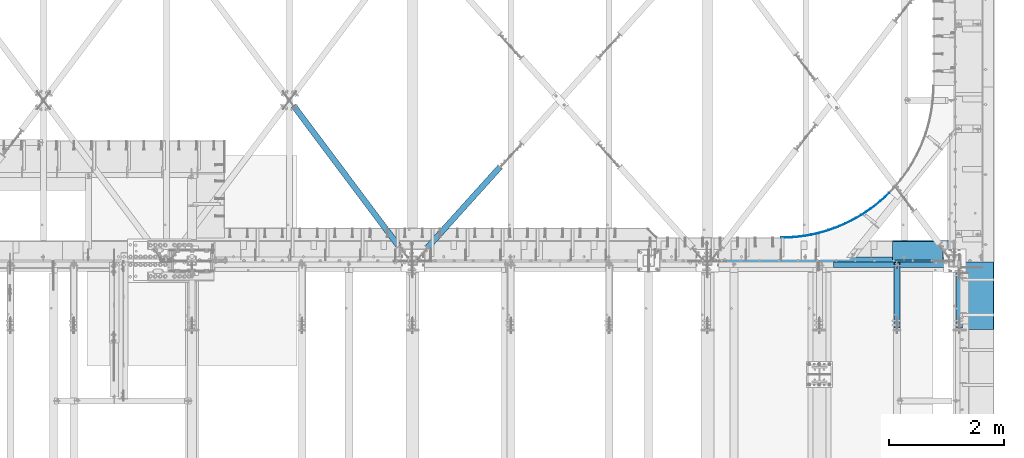
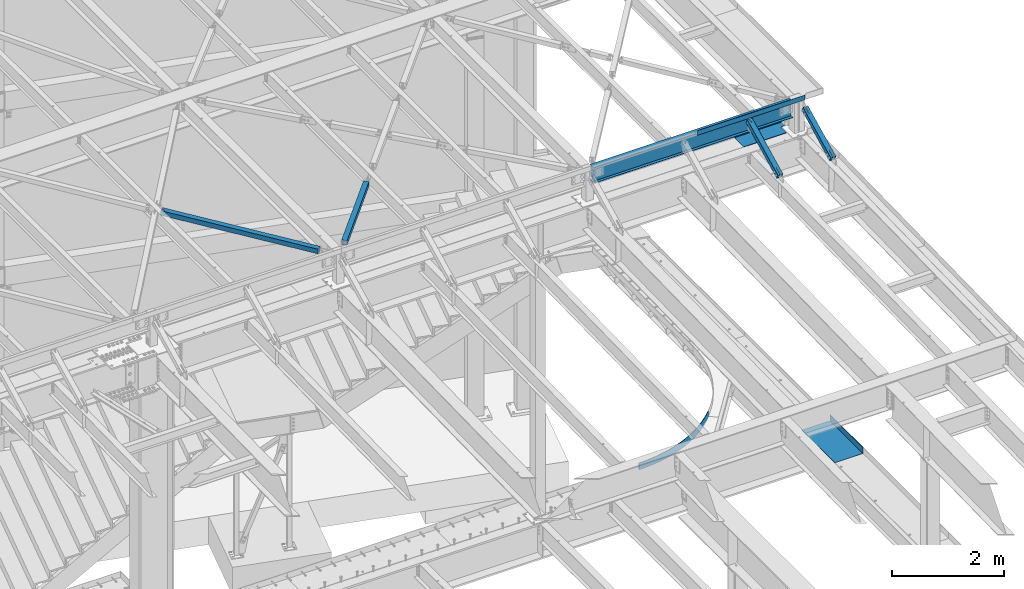
# One storey, part 1165 of 1763: 7 beams, 2 members, 8 elements without a shape of their own.
"""IFC2X3 building model written with IfcOpenShell, lengths in millimetres."""

from ifc_helpers import new_model, si_unit, frame, origin_with_axes, place, context, subcontext, project, spatial, faceted_brep, material, type_object, element, aggregate, save


model = new_model("IFC2X3")

# Units and contexts
model_context = context("Model", 3, precision=1e-05, world=origin_with_axes())
body_context = subcontext(model_context, "Body", "Model", "MODEL_VIEW")
ifc_project = project(units=[si_unit("LENGTHUNIT", "METRE", prefix="MILLI"), si_unit("AREAUNIT", "SQUARE_METRE"), si_unit("VOLUMEUNIT", "CUBIC_METRE"), si_unit("MASSUNIT", "GRAM", prefix="KILO"), si_unit("TIMEUNIT", "SECOND"), si_unit("PLANEANGLEUNIT", "RADIAN"), si_unit("SOLIDANGLEUNIT", "STERADIAN"), si_unit("THERMODYNAMICTEMPERATUREUNIT", "DEGREE_CELSIUS"), si_unit("LUMINOUSINTENSITYUNIT", "LUMEN")], contexts=[model_context])

# Site, building, storey
site_placement = place(None, origin_with_axes())
site = spatial("IfcSite", under=ifc_project, at=site_placement, CompositionType="ELEMENT")
building_placement = place(site_placement, origin_with_axes())
building = spatial("IfcBuilding", under=site, at=building_placement, Name="Undefined", CompositionType="ELEMENT")
storey_placement = place(building_placement, origin_with_axes())
storey = spatial("IfcBuildingStorey", under=building, at=storey_placement, Name="Undefined", CompositionType="ELEMENT", Elevation=0.0)

# Assembly, beam
assembly_1_placement = place(storey_placement, origin_with_axes())
assembly_1 = element("IfcElementAssembly", 1, at=assembly_1_placement, inside=storey, Name="BEAM", AssemblyPlace="NOTDEFINED", PredefinedType="RIGID_FRAME")
ifc_material_1 = material(Name="STEEL/A36")
beam_type_1 = type_object("IfcBeamType", Name="L4X4X1/4", PredefinedType="NOTDEFINED")
beam_1_placement = place(assembly_1_placement, frame((-23782.8433674464, 52050.95, 12496.8), z_axis=(0.0, 1.0, 0.0), x_axis=(1.0, 0.0, 0.0)))
beam_1 = element("IfcBeam", 2, at=beam_1_placement, type_object=beam_type_1, material=ifc_material_1, Name="V. BRACE", ObjectType="L4X4X1/4", context=body_context, shape_type="Brep", body=[
    faceted_brep([(1998.50375037947, 44.4500000000007, 50.8000000000029), (1998.50375037947, 44.4500000000007, -44.4499999999971), (1998.50375037947, 50.7999999999938, -44.4499999999898), (1998.50375037947, 50.7999999999993, 50.8000000000029), (2212.81625000197, 44.4500000000007, -44.4499999999971), (2212.81625000197, 50.7999999999993, -44.4499999999898), (2.11002770811319e-10, -50.8000000000357, -50.799999999952), (1.96450855582952e-10, -50.8000000000338, -44.4499999999534), (-2.18278728425503e-11, 44.4500000000007, -44.450000000048), (-1.81898940354586e-10, 44.4500000000371, 50.7999999999374), (-1.96450855582952e-10, 50.8000000000393, 50.7999999999374), (-3.63797880709171e-11, 50.8000000000011, -50.8000000000538), (2212.81625000197, 50.7999999999993, -50.8000000000029), (2212.81625000197, -50.7999999999993, -50.8000000000029), (2212.81625000197, -50.7999999999993, -44.4499999999971), (2212.81625000197, 31.7499999999945, -44.4499999999971)], [[[0, 1, 2, 3]], [[4, 5, 2, 1]], [[6, 7, 8, 9, 10, 11]], [[6, 11, 12, 13]], [[7, 6, 13, 14]], [[1, 8, 7, 14, 15, 4]], [[9, 8, 1, 0]], [[10, 9, 0, 3]], [[12, 11, 10, 3, 2, 5]], [[15, 14, 13, 12, 5, 4]]]),
])

assembly_2_placement = place(storey_placement, origin_with_axes())
assembly_2 = element("IfcElementAssembly", 3, at=assembly_2_placement, inside=storey, Name="BEAM", AssemblyPlace="NOTDEFINED", PredefinedType="RIGID_FRAME")
beam_type_2 = type_object("IfcBeamType", PredefinedType="NOTDEFINED")
beam_2_placement = place(assembly_2_placement, frame((-21576.7372736984, 51509.2155, 5199.0625), z_axis=(0.0, -1.0, 0.0), x_axis=(1.0, 0.0, 0.0)))
beam_2 = element("IfcBeam", 4, at=beam_2_placement, type_object=beam_type_2, material=ifc_material_1, Name="BENT_PLATE", context=body_context, shape_type="Brep", body=[
    faceted_brep([(0.0, -4.76249999999982, -588.565499999997), (0.0, -4.76249999999982, 588.565499999997), (0.0, 4.76249999999982, 588.565499999997), (0.0, 4.76249999999982, -588.565499999997), (577.849999999999, 4.76249999999982, 588.565499999997), (577.849999999999, 4.76249999999982, -588.565499999997), (587.375, -4.76249999999982, -588.565499999997), (587.375, -4.76249999999982, 588.565499999997), (577.849999999999, 134.937496948242, 588.565499999997), (577.849999999999, 134.937496948242, -588.565499999997), (587.375, 134.937496948242, 588.565499999997), (587.375, 134.937496948242, -588.565499999997)], [[[0, 1, 2, 3]], [[3, 2, 4, 5]], [[1, 0, 6, 7]], [[5, 4, 8, 9]], [[4, 2, 1, 7, 10, 8]], [[7, 6, 11, 10]], [[6, 0, 3, 5, 9, 11]], [[10, 11, 9, 8]]]),
])
aggregate(assembly_2, [beam_2])

assembly_3_placement = place(storey_placement, origin_with_axes())
assembly_3 = element("IfcElementAssembly", 5, at=assembly_3_placement, inside=storey, Name="BEAM", AssemblyPlace="NOTDEFINED", PredefinedType="RIGID_FRAME")
beam_type_3 = type_object("IfcBeamType", PredefinedType="NOTDEFINED")
beam_3_placement = place(assembly_3_placement, frame((-24688.4513631793, 52522.4379788748, 5245.1), z_axis=(0.0, 0.0, 1.0), x_axis=(0.923270562101468, 0.384150321042218, 0.0)))
beam_3 = element("IfcBeam", 6, at=beam_3_placement, type_object=beam_type_3, material=ifc_material_1, Name="PLATE", context=body_context, shape_type="Brep", body=[
    faceted_brep([(1.82766043285983, 4.39784760903422, -76.1999999999998), (1.82766043285983, 4.39784760903422, 76.1999999999998), (98.6660821309192, -33.6277689342314, 76.1999999999998), (98.6660821309192, -33.6277689342314, -76.1999999999998), (-1.82766043286802, -4.39784760901966, 76.1999999999998), (-1.82766043286802, -4.39784760901966, -76.1999999999998), (95.3599385969715, -42.5605758801612, -76.1999999999998), (95.3599385969715, -42.5605758801612, 76.1999999999998), (196.926711149033, -67.8107503055435, 76.1999999999998), (196.926711149033, -67.8107503055435, -76.1999999999998), (193.97487310311, -76.8668133105748, -76.1999999999998), (193.97487310311, -76.8668133105748, 76.1999999999998), (296.457135514323, -98.0980753133772, 76.1999999999998), (296.457135514323, -98.0980753133772, -76.1999999999998), (293.86418154975, -107.26334752635, -76.1999999999998), (293.86418154975, -107.26334752635, 76.1999999999998), (397.102973675515, -124.442765315303, 76.1999999999998), (397.102973675515, -124.442765315303, -76.1999999999998), (394.872925720836, -133.703030490775, -76.1999999999998), (394.872925720836, -133.703030490775, 76.1999999999998), (498.708113963984, -146.803957086442, 76.1999999999998), (498.708113963984, -146.803957086442, -76.1999999999998), (496.84443104457, -156.144851635487, -76.1999999999998), (496.84443104457, -156.144851635487, 76.1999999999998), (601.114956738452, -165.146966202461, 76.1999999999998), (601.114956738452, -165.146966202461, -76.1999999999998), (599.620529611194, -174.554001471966, -76.1999999999998), (599.620529611194, -174.554001471966, 76.1999999999998), (704.164658837635, -179.443340838501, 76.1999999999998), (704.164658837635, -179.443340838501, -76.1999999999998), (703.041805507109, -188.901925584563, -76.1999999999998), (703.041805507109, -188.901925584563, 76.1999999999998), (807.697379961744, -189.670905900777, 76.1999999999998), (807.697379961744, -189.670905900777, -76.1999999999998), (806.947842084726, -199.166368921149, -76.1999999999998), (806.947842084726, -199.166368921149, 76.1999999999998), (911.552530600609, -195.813797422357, 76.1999999999998), (911.552530600609, -195.813797422357, -76.1999999999998), (911.177470784623, -205.331410312931, -76.1999999999998), (911.177470784623, -205.331410312931, 76.1999999999998), (1015.56902112392, -197.862487169776, 76.1999999999998), (1015.56902112392, -197.862487169776, -76.1999999999998), (1015.56902112391, -207.387487169792, -76.1999999999998), (1015.56902112391, -207.387487169792, 76.1999999999998), (1119.58551164723, -195.81379742219, 76.1999999999998), (1119.58551164723, -195.81379742219, -76.1999999999998), (1119.9605714632, -205.331410312763, -76.1999999999998), (1119.9605714632, -205.331410312763, 76.1999999999998), (1223.4406622861, -189.670905900428, 76.1999999999998), (1223.4406622861, -189.670905900428, -76.1999999999998), (1224.19020016311, -199.166368920814, -76.1999999999998), (1224.19020016311, -199.166368920814, 76.1999999999998), (1326.97338341022, -179.443340837999, 76.1999999999998), (1326.97338341022, -179.443340837999, -76.1999999999998), (1328.09623674073, -188.901925584061, -76.1999999999998), (1328.09623674073, -188.901925584061, 76.1999999999998), (1430.02308550943, -165.146966201792, 76.1999999999998), (1430.02308550943, -165.146966201792, -76.1999999999998), (1431.51751263667, -174.554001471297, -76.1999999999998), (1431.51751263667, -174.554001471297, 76.1999999999998), (1532.42992828391, -146.803957085605, 76.1999999999998), (1532.42992828391, -146.803957085605, -76.1999999999998), (1534.29361120332, -156.144851634635, -76.1999999999998), (1534.29361120332, -156.144851634635, 76.1999999999998), (1634.03506857241, -124.442765314292, 76.1999999999998), (1634.03506857241, -124.442765314292, -76.1999999999998), (1636.26511652707, -133.703030489771, -76.1999999999998), (1636.26511652707, -133.703030489771, 76.1999999999998), (1734.68090673362, -98.0980753122058, 76.1999999999998), (1734.68090673362, -98.0980753122058, -76.1999999999998), (1737.27386069819, -107.263347525186, -76.1999999999998), (1737.27386069819, -107.263347525186, 76.1999999999998), (1834.21133109895, -67.8107503042193, 76.1999999999998), (1834.21133109895, -67.8107503042193, -76.1999999999998), (1837.16316914487, -76.866813309236, -76.1999999999998), (1837.16316914487, -76.866813309236, 76.1999999999998), (1932.47196011711, -33.6277689327471, 76.1999999999998), (1932.47196011711, -33.6277689327471, -76.1999999999998), (1935.77810365104, -42.5605758786769, -76.1999999999998), (1935.77810365104, -42.5605758786769, 76.1999999999998), (2029.31038181521, 4.39784761067858, 76.1999999999998), (2029.31038181521, 4.39784761067858, -76.1999999999998), (2032.96570268093, -4.3978476073753, 76.1999999999998), (2032.96570268093, -4.3978476073753, -76.1999999999998)], [[[0, 1, 2, 3]], [[4, 5, 6, 7]], [[5, 4, 1, 0]], [[3, 2, 8, 9]], [[7, 6, 10, 11]], [[9, 8, 12, 13]], [[11, 10, 14, 15]], [[13, 12, 16, 17]], [[15, 14, 18, 19]], [[17, 16, 20, 21]], [[19, 18, 22, 23]], [[21, 20, 24, 25]], [[23, 22, 26, 27]], [[25, 24, 28, 29]], [[27, 26, 30, 31]], [[29, 28, 32, 33]], [[31, 30, 34, 35]], [[33, 32, 36, 37]], [[35, 34, 38, 39]], [[37, 36, 40, 41]], [[39, 38, 42, 43]], [[41, 40, 44, 45]], [[43, 42, 46, 47]], [[45, 44, 48, 49]], [[47, 46, 50, 51]], [[49, 48, 52, 53]], [[51, 50, 54, 55]], [[53, 52, 56, 57]], [[55, 54, 58, 59]], [[57, 56, 60, 61]], [[59, 58, 62, 63]], [[61, 60, 64, 65]], [[63, 62, 66, 67]], [[65, 64, 68, 69]], [[67, 66, 70, 71]], [[69, 68, 72, 73]], [[71, 70, 74, 75]], [[73, 72, 76, 77]], [[75, 74, 78, 79]], [[77, 76, 80, 81]], [[76, 72, 68, 64, 60, 56, 52, 48, 44, 40, 36, 32, 28, 24, 20, 16, 12, 8, 2, 1, 4, 7, 11, 15, 19, 23, 27, 31, 35, 39, 43, 47, 51, 55, 59, 63, 67, 71, 75, 79, 82, 80]], [[79, 78, 83, 82]], [[78, 74, 70, 66, 62, 58, 54, 50, 46, 42, 38, 34, 30, 26, 22, 18, 14, 10, 6, 5, 0, 3, 9, 13, 17, 21, 25, 29, 33, 37, 41, 45, 49, 53, 57, 61, 65, 69, 73, 77, 81, 83]], [[82, 83, 81, 80]]]),
])
aggregate(assembly_3, [beam_3])

assembly_4_placement = place(storey_placement, origin_with_axes())
assembly_4 = element("IfcElementAssembly", 7, at=assembly_4_placement, inside=storey, Name="H. BRACE", AssemblyPlace="NOTDEFINED", PredefinedType="RIGID_FRAME")
ifc_material_2 = material()
beam_type_4 = type_object("IfcBeamType", Name="HSS4X4X3/8", PredefinedType="NOTDEFINED")
beam_4_placement = place(assembly_4_placement, frame((-29400.5296174484, 53960.2116756962, 12371.3875), z_axis=(0.0, 0.0, 1.0), x_axis=(-0.669524421073345, -0.742790044081369, 0.0)))
beam_4 = element("IfcBeam", 8, at=beam_4_placement, type_object=beam_type_4, material=ifc_material_2, Name="H. BRACE", ObjectType="HSS4X4X3/8", context=body_context, shape_type="Brep", body=[
    faceted_brep([(280.94314391946, 41.2749999996377, -41.2749999999996), (280.943143919689, -41.2750000002634, -41.2749999999996), (2162.19987088826, -41.2750000023079, -41.2749999999996), (2162.19987088803, 41.2749999976004, -41.2749999999996), (280.943143919689, -41.2750000002634, 41.2749999999996), (2162.19987088826, -41.2750000023079, 41.2749999999996), (280.94314391946, 41.2749999996377, 41.2749999999996), (2162.19987088803, 41.2749999976004, 41.2749999999996), (280.943143919434, 50.7999999996318, -50.7999999999993), (280.943143919434, 50.7999999996318, 50.7999999999993), (2162.19987088801, 50.7999999975946, 50.7999999999993), (2162.19987088801, 50.7999999975946, -50.7999999999993), (280.943143919714, -50.8000000002576, 50.7999999999993), (2162.19987088829, -50.8000000022948, 50.7999999999993), (280.943143919714, -50.8000000002576, -50.7999999999993), (2162.19987088829, -50.8000000022948, -50.7999999999993)], [[[0, 1, 2, 3]], [[1, 4, 5, 2]], [[4, 6, 7, 5]], [[6, 0, 3, 7]], [[8, 9, 10, 11]], [[9, 12, 13, 10]], [[12, 14, 15, 13]], [[14, 8, 11, 15]], [[13, 15, 11, 10], [5, 7, 3, 2]], [[14, 12, 9, 8], [6, 4, 1, 0]]]),
])
aggregate(assembly_4, [beam_4])

assembly_5_placement = place(storey_placement, origin_with_axes())
assembly_5 = element("IfcElementAssembly", 9, at=assembly_5_placement, inside=storey, Name="H. BRACE", AssemblyPlace="NOTDEFINED", PredefinedType="RIGID_FRAME")
beam_5_placement = place(assembly_5_placement, frame((-31160.109616455, 52120.8000006229, 12371.3875), z_axis=(0.0, 0.0, 1.0), x_axis=(-0.599563330174951, 0.800327316233504, 0.0)))
beam_5 = element("IfcBeam", 10, at=beam_5_placement, type_object=beam_type_4, material=ifc_material_2, Name="H. BRACE", ObjectType="HSS4X4X3/8", context=body_context, shape_type="Brep", body=[
    faceted_brep([(3374.28637060242, 6.35001353249936, 50.7999999999993), (3297.12917929493, 6.35000740562646, 50.7999999999993), (3297.12917929493, 6.35000740562646, 41.2749999999996), (3374.28637060242, 6.35001353249936, 41.2749999999996), (3297.12918030329, -6.34999259426877, 50.7999999999993), (3297.12918030329, -6.34999259426877, 41.2749999999996), (3374.28637060239, -6.34998646745407, 50.7999999999993), (3374.28637060239, -6.34998646745407, 41.2749999999996), (3374.28637060242, 6.35001353249936, -41.2749999999996), (3297.12917929493, 6.35000740562646, -41.2749999999996), (3297.12917929493, 6.35000740562646, -50.7999999999993), (3374.28637060242, 6.35001353249936, -50.7999999999993), (3297.12918030329, -6.34999259426877, -41.2749999999996), (3297.12918030329, -6.34999259426877, -50.7999999999993), (3374.28637060239, -6.34998646745407, -41.2749999999996), (3374.28637060239, -6.34998646745407, -50.7999999999993), (318.597506324484, 41.2750000002652, 41.2749999999996), (318.597506324484, 41.2750000002652, -41.2749999999996), (3374.28637060252, 41.2750000040196, -41.2749999999996), (3374.28637060252, 41.2750000040196, 41.2749999999996), (3374.28637060229, -41.2749999957396, 41.2749999999996), (318.597506324251, -41.2749999994867, 41.2749999999996), (318.597506324251, -41.2749999994867, -41.2749999999996), (3374.28637060229, -41.2749999957396, -41.2749999999996), (318.597506324222, -50.799999999459, -50.7999999999993), (318.597506324222, -50.799999999459, 50.7999999999993), (318.597506324513, 50.8000000002376, 50.7999999999993), (318.597506324513, 50.8000000002376, -50.7999999999993), (3374.28637060255, 50.800000003992, 50.7999999999993), (3374.28637060255, 50.800000003992, -50.7999999999993), (3374.28637060226, -50.7999999957083, -50.7999999999993), (3374.28637060226, -50.7999999957083, 50.7999999999993)], [[[0, 1, 2, 3]], [[4, 5, 2, 1]], [[6, 7, 5, 4]], [[8, 9, 10, 11]], [[12, 13, 10, 9]], [[14, 15, 13, 12]], [[16, 17, 18, 19]], [[20, 21, 16, 19, 3, 2, 5, 7]], [[22, 21, 20, 23]], [[9, 8, 18, 17, 22, 23, 14, 12]], [[24, 25, 26, 27], [16, 21, 22, 17]], [[27, 26, 28, 29]], [[19, 18, 8, 11, 29, 28, 0, 3]], [[30, 24, 27, 29, 11, 10, 13, 15]], [[25, 24, 30, 31]], [[1, 0, 28, 26, 25, 31, 6, 4]], [[31, 30, 15, 14, 23, 20, 7, 6]]]),
])
aggregate(assembly_5, [beam_5])

# Assembly, member
assembly_6_placement = place(storey_placement, origin_with_axes())
assembly_6 = element("IfcElementAssembly", 11, at=assembly_6_placement, inside=storey, Name="BEAM", AssemblyPlace="NOTDEFINED", PredefinedType="RIGID_FRAME")
member_type = type_object("IfcMemberType", Name="HSS4X4X1/2", PredefinedType="NOTDEFINED")
member_1_placement = place(assembly_6_placement, frame((-22678.4622736984, 50822.4762411655, 11720.6381213767), z_axis=(-1.0, 0.0, 0.0), x_axis=(0.0, 0.894427191199916, 0.447213595099959)))
member_1 = element("IfcMember", 12, at=member_1_placement, type_object=member_type, material=ifc_material_2, Name="BEAM", ObjectType="HSS4X4X1/2", context=body_context, shape_type="Brep", body=[
    faceted_brep([(1394.22226894295, -50.8000000020184, -7.9375), (1394.2222689429, -38.1000000020122, -7.9375), (1321.53025774739, -38.1000000019103, -7.9375), (1327.88025774027, -50.8000000019219, -7.9375), (1321.53025774739, -38.1000000019103, 7.9375), (1327.88025774027, -50.8000000019219, 7.9375), (1394.22226894295, -50.8000000020184, 7.9375), (1394.2222689429, -38.1000000020122, 7.9375), (1394.22226894266, 38.0999999980304, -7.9375), (1394.22226894262, 50.799999998042, -7.9375), (1277.08025779721, 50.7999999982076, -7.9375), (1283.4302577901, 38.0999999981887, -7.9375), (1277.08025779721, 50.7999999982076, 7.9375), (1283.4302577901, 38.0999999981887, 7.9375), (1394.22226894266, 38.0999999980304, 7.9375), (1394.22226894262, 50.799999998042, 7.9375), (166.342448712407, -38.100000000255, 38.0999999999985), (166.342448712276, 38.0999999997875, 38.0999999999985), (1394.22226894266, 38.0999999980304, 38.0999999999985), (1394.2222689429, -38.1000000020122, 38.0999999999985), (1394.2222689429, -38.1000000020122, -38.0999999999985), (166.342448712407, -38.100000000255, -38.0999999999985), (166.342448712407, -38.100000000255, -7.93749999974898), (317.154945941751, -38.1000000004715, -7.93749999987267), (320.192495686126, -38.1000000004769, -7.33329378918279), (322.767606017376, -38.1000000004806, -5.61266007554514), (324.488239731007, -38.1000000004842, -3.03754974427284), (325.092445941693, -38.1000000004842, 2.5465851649642e-10), (324.488239731007, -38.1000000004842, 3.03754974465119), (322.767606017376, -38.1000000004806, 5.61266007592349), (320.192495686126, -38.1000000004788, 7.33329378956478), (317.154945941751, -38.1000000004733, 7.93750000025466), (166.342448712407, -38.100000000255, 7.93750000025466), (166.342448712276, 38.0999999997875, -38.0999999999985), (1394.22226894266, 38.0999999980304, -38.0999999999985), (166.342448712276, 38.0999999997875, 7.93750000025466), (166.342448712254, 50.7999999997955, 7.93750000025466), (317.154945941591, 50.7999999995791, 7.93750000025466), (317.15494594162, 38.0999999995711, 7.93750000025466), (320.192495685966, 50.7999999995736, 7.33329378956478), (320.192495685995, 38.0999999995693, 7.33329378956478), (322.767606017216, 50.7999999995718, 5.61266007592349), (322.767606017245, 38.0999999995638, 5.61266007592349), (324.488239730847, 50.7999999995682, 3.03754974465119), (324.488239730868, 38.0999999995638, 3.03754974465119), (325.092445941533, 50.7999999995682, 2.5465851649642e-10), (325.092445941555, 38.0999999995583, 2.5465851649642e-10), (324.488239730847, 50.7999999995682, -3.03754974427284), (324.488239730861, 38.0999999995602, -3.03754974427284), (322.767606017209, 50.79999999957, -5.61266007554514), (322.767606017245, 38.0999999995638, -5.61266007554514), (320.192495685966, 50.7999999995754, -7.33329378918279), (320.19249568598, 38.0999999995674, -7.33329378918279), (317.154945941591, 50.7999999995791, -7.93749999987267), (317.154945941606, 38.0999999995693, -7.93749999987267), (166.342448712254, 50.7999999997955, -7.93749999974898), (166.342448712276, 38.0999999997875, -7.93749999974898), (166.342448712254, 50.7999999997955, -50.7999999999993), (166.342448712421, -50.8000000002612, -50.7999999999993), (166.342448712421, -50.8000000002612, -7.93749999974898), (317.154945941773, -50.8000000004795, -7.93749999987267), (320.192495686155, -50.8000000004831, -7.33329378918279), (322.767606017391, -50.8000000004868, -5.61266007554514), (324.488239731028, -50.800000000494, -3.03754974427284), (325.092445941715, -50.8000000004904, 2.5465851649642e-10), (324.488239731028, -50.800000000494, 3.03754974465119), (322.767606017405, -50.8000000004849, 5.61266007592349), (320.192495686155, -50.8000000004849, 7.33329378956478), (317.154945941787, -50.8000000004795, 7.93750000025466), (166.342448712421, -50.8000000002612, 7.93750000025466), (166.342448712421, -50.8000000002612, 50.7999999999993), (166.342448712254, 50.7999999997955, 50.7999999999993), (1394.22226894295, -50.8000000020184, 50.7999999999993), (1394.22226894262, 50.799999998042, 50.7999999999993), (1394.22226894262, 50.799999998042, -50.7999999999993), (1394.22226894295, -50.8000000020184, -50.7999999999993)], [[[0, 1, 2, 3]], [[3, 2, 4, 5]], [[6, 5, 4, 7]], [[8, 9, 10, 11]], [[11, 10, 12, 13]], [[14, 13, 12, 15]], [[16, 17, 18, 19]], [[2, 1, 20, 21, 22, 23, 24, 25, 26, 27, 28, 29, 30, 31, 32, 16, 19, 7, 4]], [[33, 21, 20, 34]], [[35, 36, 37, 38]], [[38, 37, 39, 40]], [[40, 39, 41, 42]], [[42, 41, 43, 44]], [[44, 43, 45, 46]], [[46, 45, 47, 48]], [[48, 47, 49, 50]], [[50, 49, 51, 52]], [[52, 51, 53, 54]], [[54, 53, 55, 56]], [[21, 33, 56, 55, 57, 58, 59, 22]], [[60, 23, 22, 59]], [[61, 24, 23, 60]], [[62, 25, 24, 61]], [[63, 26, 25, 62]], [[64, 27, 26, 63]], [[65, 28, 27, 64]], [[66, 29, 28, 65]], [[67, 30, 29, 66]], [[68, 31, 30, 67]], [[69, 32, 31, 68]], [[70, 71, 36, 35, 17, 16, 32, 69]], [[71, 70, 72, 73]], [[19, 18, 14, 15, 73, 72, 6, 7]], [[10, 9, 74, 57, 55, 53, 51, 49, 47, 45, 43, 41, 39, 37, 36, 71, 73, 15, 12]], [[58, 57, 74, 75]], [[72, 70, 69, 68, 67, 66, 65, 64, 63, 62, 61, 60, 59, 58, 75, 0, 3, 5, 6]], [[75, 74, 9, 8, 34, 20, 1, 0]], [[18, 17, 35, 38, 40, 42, 44, 46, 48, 50, 52, 54, 56, 33, 34, 8, 11, 13, 14]]]),
])
aggregate(assembly_6, [member_1])

assembly_7_placement = place(storey_placement, origin_with_axes())
assembly_7 = element("IfcElementAssembly", 13, at=assembly_7_placement, inside=storey, Name="BEAM", AssemblyPlace="NOTDEFINED", PredefinedType="RIGID_FRAME")
member_2_placement = place(assembly_7_placement, frame((-21589.4406443556, 50822.4448748459, 11720.6374724139), z_axis=(-1.0, 0.0, 0.0), x_axis=(0.0, 0.894427191199916, 0.447213595099959)))
member_2 = element("IfcMember", 14, at=member_2_placement, type_object=member_type, material=ifc_material_2, Name="BEAM", ObjectType="HSS4X4X1/2", context=body_context, shape_type="Brep", body=[
    faceted_brep([(1284.21483573192, -50.8000000018583, -7.93749999961074), (1284.2148357319, -38.1000000018521, -7.93749999961074), (1133.4023357259, -38.1000000016375, -7.93749999973443), (1133.40233572593, -50.8000000016418, -7.93749999973443), (1130.36478598152, -38.1000000016338, -7.33329378904455), (1130.36478598155, -50.8000000016382, -7.33329378904455), (1127.78967565028, -38.1000000016265, -5.61266007540689), (1127.7896756503, -50.8000000016364, -5.61266007540689), (1126.06904193664, -38.1000000016265, -3.03754974413459), (1126.06904193667, -50.8000000016364, -3.03754974413459), (1125.46483572596, -38.1000000016265, 3.92901711165905e-10), (1125.46483572599, -50.8000000016309, 3.92901711165905e-10), (1126.06904193664, -38.1000000016265, 3.03754974478943), (1126.06904193667, -50.8000000016345, 3.03754974478943), (1127.78967565028, -38.1000000016265, 5.61266007606173), (1127.7896756503, -50.8000000016345, 5.61266007606173), (1130.36478598152, -38.100000001632, 7.33329378970302), (1130.36478598155, -50.80000000164, 7.33329378970302), (1133.40233572589, -38.1000000016338, 7.9375000003929), (1133.40233572592, -50.8000000016418, 7.9375000003929), (1284.21483573192, -50.8000000018583, 7.9375000003929), (1284.2148357319, -38.1000000018521, 7.9375000003929), (1284.21483573178, 38.0999999981941, -7.93749999961074), (1284.21483573176, 50.7999999982021, -7.93749999961074), (1133.40233572575, 50.7999999984168, -7.93749999973443), (1133.40233572576, 38.0999999984069, -7.93749999973443), (1130.36478598137, 50.7999999984186, -7.33329378904455), (1130.36478598139, 38.0999999984106, -7.33329378904455), (1127.78967565011, 50.7999999984204, -5.61266007540689), (1127.78967565014, 38.0999999984142, -5.61266007540689), (1126.06904193648, 50.7999999984222, -3.03754974413459), (1126.06904193651, 38.0999999984178, -3.03754974413459), (1125.4648357258, 50.7999999984277, 3.92901711165905e-10), (1125.46483572582, 38.0999999984178, 3.92901711165905e-10), (1126.06904193648, 50.7999999984222, 3.03754974478943), (1126.06904193651, 38.0999999984178, 3.03754974478943), (1127.78967565011, 50.7999999984222, 5.61266007606173), (1127.78967565014, 38.0999999984142, 5.61266007606173), (1130.36478598136, 50.7999999984186, 7.33329378970302), (1130.36478598138, 38.0999999984087, 7.33329378970302), (1133.40233572573, 50.7999999984149, 7.9375000003929), (1133.40233572575, 38.0999999984069, 7.9375000003929), (1284.21483573178, 38.0999999981941, 7.9375000003929), (1284.21483573176, 50.7999999982021, 7.9375000003929), (166.342448712407, -38.100000000255, 38.0999999999985), (166.342448712276, 38.0999999997875, 38.0999999999985), (1284.21483573178, 38.0999999981941, 38.0999999999985), (1284.2148357319, -38.1000000018521, 38.0999999999985), (1284.2148357319, -38.1000000018521, -38.0999999999985), (166.342448712407, -38.100000000255, -38.0999999999985), (166.342448712407, -38.100000000255, -7.93749999974898), (317.154945941751, -38.1000000004715, -7.93749999987267), (320.192495686126, -38.1000000004769, -7.33329378918279), (322.767606017376, -38.1000000004806, -5.61266007554514), (324.488239731007, -38.1000000004842, -3.03754974427284), (325.092445941693, -38.1000000004842, 2.5465851649642e-10), (324.488239731007, -38.1000000004842, 3.03754974465119), (322.767606017376, -38.1000000004806, 5.61266007592349), (320.192495686126, -38.1000000004788, 7.33329378956478), (317.154945941751, -38.1000000004733, 7.93750000025466), (166.342448712407, -38.100000000255, 7.93750000025466), (166.342448712276, 38.0999999997875, -38.0999999999985), (1284.21483573178, 38.0999999981941, -38.0999999999985), (166.342448712276, 38.0999999997875, 7.93750000025466), (166.342448712254, 50.7999999997955, 7.93750000025466), (317.154945941591, 50.7999999995791, 7.93750000025466), (317.15494594162, 38.0999999995711, 7.93750000025466), (320.192495685966, 50.7999999995736, 7.33329378956478), (320.192495685995, 38.0999999995693, 7.33329378956478), (322.767606017216, 50.7999999995718, 5.61266007592349), (322.767606017245, 38.0999999995638, 5.61266007592349), (324.488239730847, 50.7999999995682, 3.03754974465119), (324.488239730868, 38.0999999995638, 3.03754974465119), (325.092445941533, 50.7999999995682, 2.5465851649642e-10), (325.092445941555, 38.0999999995583, 2.5465851649642e-10), (324.488239730847, 50.7999999995682, -3.03754974427284), (324.488239730861, 38.0999999995602, -3.03754974427284), (322.767606017209, 50.79999999957, -5.61266007554514), (322.767606017245, 38.0999999995638, -5.61266007554514), (320.192495685966, 50.7999999995754, -7.33329378918279), (320.19249568598, 38.0999999995674, -7.33329378918279), (317.154945941591, 50.7999999995791, -7.93749999987267), (317.154945941606, 38.0999999995693, -7.93749999987267), (166.342448712254, 50.7999999997955, -7.93749999974898), (166.342448712276, 38.0999999997875, -7.93749999974898), (166.342448712254, 50.7999999997955, -50.7999999999993), (166.342448712421, -50.8000000002612, -50.7999999999993), (166.342448712421, -50.8000000002612, -7.93749999974898), (317.154945941773, -50.8000000004795, -7.93749999987267), (320.192495686155, -50.8000000004831, -7.33329378918279), (322.767606017391, -50.8000000004868, -5.61266007554514), (324.488239731028, -50.800000000494, -3.03754974427284), (325.092445941715, -50.8000000004904, 2.5465851649642e-10), (324.488239731028, -50.800000000494, 3.03754974465119), (322.767606017405, -50.8000000004849, 5.61266007592349), (320.192495686155, -50.8000000004849, 7.33329378956478), (317.154945941787, -50.8000000004795, 7.93750000025466), (166.342448712421, -50.8000000002612, 7.93750000025466), (166.342448712421, -50.8000000002612, 50.7999999999993), (166.342448712254, 50.7999999997955, 50.7999999999993), (1284.21483573192, -50.8000000018583, 50.7999999999993), (1284.21483573176, 50.7999999982021, 50.7999999999993), (1284.21483573176, 50.7999999982021, -50.7999999999993), (1284.21483573192, -50.8000000018583, -50.7999999999993)], [[[0, 1, 2, 3]], [[3, 2, 4, 5]], [[5, 4, 6, 7]], [[7, 6, 8, 9]], [[9, 8, 10, 11]], [[11, 10, 12, 13]], [[13, 12, 14, 15]], [[15, 14, 16, 17]], [[17, 16, 18, 19]], [[20, 19, 18, 21]], [[22, 23, 24, 25]], [[25, 24, 26, 27]], [[27, 26, 28, 29]], [[29, 28, 30, 31]], [[31, 30, 32, 33]], [[33, 32, 34, 35]], [[35, 34, 36, 37]], [[37, 36, 38, 39]], [[39, 38, 40, 41]], [[42, 41, 40, 43]], [[44, 45, 46, 47]], [[16, 14, 12, 10, 8, 6, 4, 2, 1, 48, 49, 50, 51, 52, 53, 54, 55, 56, 57, 58, 59, 60, 44, 47, 21, 18]], [[61, 49, 48, 62]], [[63, 64, 65, 66]], [[66, 65, 67, 68]], [[68, 67, 69, 70]], [[70, 69, 71, 72]], [[72, 71, 73, 74]], [[74, 73, 75, 76]], [[76, 75, 77, 78]], [[78, 77, 79, 80]], [[80, 79, 81, 82]], [[82, 81, 83, 84]], [[49, 61, 84, 83, 85, 86, 87, 50]], [[88, 51, 50, 87]], [[89, 52, 51, 88]], [[90, 53, 52, 89]], [[91, 54, 53, 90]], [[92, 55, 54, 91]], [[93, 56, 55, 92]], [[94, 57, 56, 93]], [[95, 58, 57, 94]], [[96, 59, 58, 95]], [[97, 60, 59, 96]], [[98, 99, 64, 63, 45, 44, 60, 97]], [[99, 98, 100, 101]], [[47, 46, 42, 43, 101, 100, 20, 21]], [[38, 36, 34, 32, 30, 28, 26, 24, 23, 102, 85, 83, 81, 79, 77, 75, 73, 71, 69, 67, 65, 64, 99, 101, 43, 40]], [[86, 85, 102, 103]], [[100, 98, 97, 96, 95, 94, 93, 92, 91, 90, 89, 88, 87, 86, 103, 0, 3, 5, 7, 9, 11, 13, 15, 17, 19, 20]], [[103, 102, 23, 22, 62, 48, 1, 0]], [[46, 45, 63, 66, 68, 70, 72, 74, 76, 78, 80, 82, 84, 61, 62, 22, 25, 27, 29, 31, 33, 35, 37, 39, 41, 42]]]),
])
aggregate(assembly_7, [member_2])

# Beam
ifc_material_3 = material(Name="STEEL/A992")
beam_type_5 = type_object("IfcBeamType", Name="W14X22", PredefinedType="NOTDEFINED")
beam_6_placement = place(assembly_1_placement, frame((-25976.6096174484, 52120.8, 12271.375), z_axis=(0.0, 0.0, 1.0), x_axis=(1.0, 0.0, 0.0)))
beam_6 = element("IfcBeam", 15, at=beam_6_placement, type_object=beam_type_5, material=ifc_material_3, Name="BEAM", ObjectType="W14X22", context=body_context, shape_type="Brep", body=[
    faceted_brep([(88.8999999999942, 63.5, -174.625), (88.8999999999942, 63.5, -166.6875), (4192.27, 63.5, -166.6875), (4192.27, 63.5, -174.625), (88.8999999999942, 3.17500000000291, -166.6875), (4192.27, 3.17500000000291, -166.6875), (88.8999999999942, 3.17500000000291, 166.6875), (4192.27, 3.17500000000291, 166.6875), (88.8999999999942, 63.5, 166.6875), (4192.27, 63.5, 166.6875), (88.8999999999942, 63.5, 174.625), (4192.27, 63.5, 174.625), (88.8999999999942, -63.5, 174.625), (4192.27, -63.5, 174.625), (88.8999999999942, -63.5, 166.6875), (4192.27, -63.5, 166.6875), (88.8999999999942, -3.17500000000291, 166.6875), (4192.27, -3.17500000000291, 166.6875), (88.8999999999942, -3.17500000000291, -166.6875), (4192.27, -3.17500000000291, -166.6875), (88.8999999999942, -63.5, -166.6875), (4192.27, -63.5, -166.6875), (88.8999999999942, -63.5, -174.625), (4192.27, -63.5, -174.625)], [[[0, 1, 2, 3]], [[1, 4, 5, 2]], [[4, 6, 7, 5]], [[6, 8, 9, 7]], [[8, 10, 11, 9]], [[10, 12, 13, 11]], [[12, 14, 15, 13]], [[14, 16, 17, 15]], [[16, 18, 19, 17]], [[18, 20, 21, 19]], [[20, 22, 23, 21]], [[22, 0, 3, 23]], [[5, 7, 9, 11, 13, 15, 17, 19, 21, 23, 3, 2]], [[22, 20, 18, 16, 14, 12, 10, 8, 6, 4, 1, 0]]]),
])

aggregate(assembly_1, [beam_1, beam_6])

# Assembly, beam
assembly_8_placement = place(storey_placement, origin_with_axes())
assembly_8 = element("IfcElementAssembly", 16, at=assembly_8_placement, inside=storey, Name="BEAM", AssemblyPlace="NOTDEFINED", PredefinedType="RIGID_FRAME")
beam_type_6 = type_object("IfcBeamType", PredefinedType="NOTDEFINED")
beam_7_placement = place(assembly_8_placement, frame((-22269.5007736984, 52133.5000002128, 11752.2624917654), z_axis=(-1.0, 0.0, 0.0), x_axis=(0.0, 1.0, 0.0)))
beam_7 = element("IfcBeam", 17, at=beam_7_placement, type_object=beam_type_6, material=ifc_material_1, Name="BENT_PLATE", context=body_context, shape_type="Brep", body=[
    faceted_brep([(203.200002838494, -4.76250000000073, -393.086156038207), (203.200002838494, 4.76250000000073, -393.086156038207), (203.200002838494, 4.76250000000073, -485.161), (203.200002838494, -4.76250000000073, -485.161), (0.0, -4.76250000000073, -393.086156038207), (0.0, 4.76250000000073, -393.086156038207), (336.549987792969, 4.76250000000073, 485.161), (0.0, 4.76250000000073, 485.161), (0.0, -4.76250000000073, 485.161), (327.024987792975, -4.76250000000073, 485.161), (327.024987792975, -122.237499999999, 485.161), (336.549987792969, -122.237499999999, 485.161), (336.549987792969, 4.76250000000073, -485.161), (336.549987792969, -122.237499999999, -485.161), (327.024987792975, -122.237499999999, -485.161), (327.024987792975, -4.76250000000073, -485.161)], [[[0, 1, 2, 3]], [[4, 5, 1, 0]], [[6, 7, 8, 9, 10, 11]], [[12, 6, 11, 13]], [[10, 14, 13, 11]], [[9, 15, 14, 10]], [[12, 13, 14, 15, 3, 2]], [[7, 6, 12, 2, 1, 5]], [[8, 7, 5, 4]], [[15, 9, 8, 4, 0, 3]]]),
])
aggregate(assembly_8, [beam_7])

save(model, "model.ifc")
